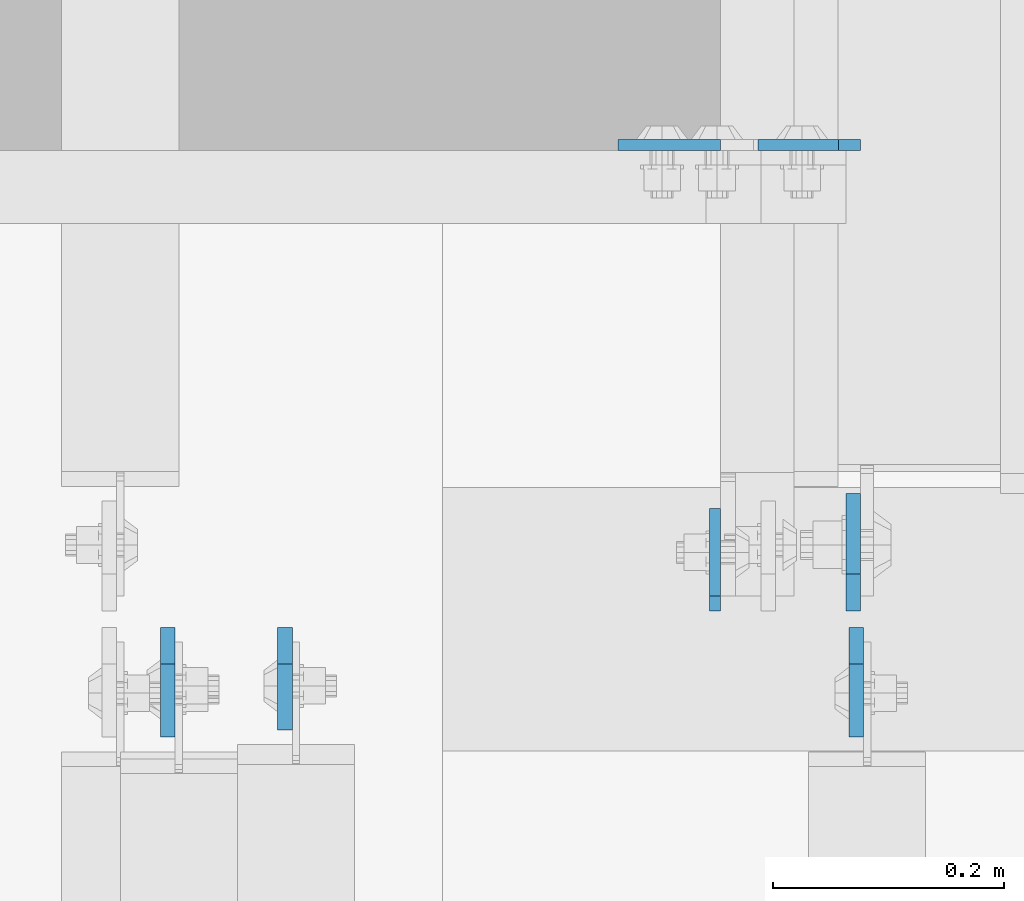
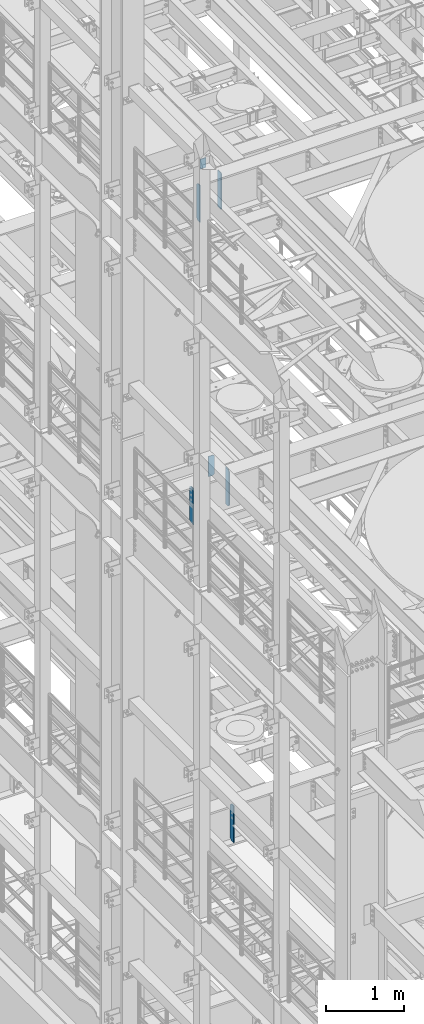
# One storey, part 1554 of 1876: 7 plates, 5 elements without a shape of their own.
"""IFC2X3 building model written with IfcOpenShell, lengths in millimetres."""

from ifc_helpers import new_model, si_unit, frame, origin_with_axes, place, context, subcontext, project, spatial, faceted_brep, material, type_object, element, aggregate, save


model = new_model("IFC2X3")

# Units and contexts
model_context = context("Model", 3, precision=1e-05, world=origin_with_axes())
body_context = subcontext(model_context, "Body", "Model", "MODEL_VIEW")
ifc_project = project(units=[si_unit("LENGTHUNIT", "METRE", prefix="MILLI"), si_unit("AREAUNIT", "SQUARE_METRE"), si_unit("VOLUMEUNIT", "CUBIC_METRE"), si_unit("MASSUNIT", "GRAM", prefix="KILO"), si_unit("TIMEUNIT", "SECOND"), si_unit("PLANEANGLEUNIT", "RADIAN"), si_unit("SOLIDANGLEUNIT", "STERADIAN"), si_unit("THERMODYNAMICTEMPERATUREUNIT", "DEGREE_CELSIUS"), si_unit("LUMINOUSINTENSITYUNIT", "LUMEN")], contexts=[model_context])

# Site, building, storey
site_placement = place(None, origin_with_axes())
site = spatial("IfcSite", under=ifc_project, at=site_placement, CompositionType="ELEMENT")
building_placement = place(site_placement, origin_with_axes())
building = spatial("IfcBuilding", under=site, at=building_placement, Name="Undefined", CompositionType="ELEMENT")
storey_placement = place(building_placement, origin_with_axes())
storey = spatial("IfcBuildingStorey", under=building, at=storey_placement, Name="Undefined", CompositionType="ELEMENT", Elevation=0.0)

# Assembly, plate
assembly_1_placement = place(storey_placement, origin_with_axes())
assembly_1 = element("IfcElementAssembly", 1, at=assembly_1_placement, inside=storey, Name="BEAM", AssemblyPlace="NOTDEFINED", PredefinedType="RIGID_FRAME")
ifc_material = material(Name="STEEL/A36")
plate_type_1 = type_object("IfcPlateType", PredefinedType="NOTDEFINED")
plate_1_placement = place(assembly_1_placement, frame((1473.2, 1935.1625, 17957.8), z_axis=(-1.0, 0.0, 0.0), x_axis=(0.0, 0.0, -1.0)))
plate_1 = element("IfcPlate", 2, at=plate_1_placement, type_object=plate_type_1, material=ifc_material, Name="PLATE", context=body_context, shape_type="Brep", body=[
    faceted_brep([(0.0, -4.76249999999982, 0.0), (0.0, -4.76249999999982, 88.9000015258789), (0.0, 4.76249999999982, 88.9000015258789), (0.0, 4.76249999999982, 0.0), (152.399993896484, -4.76249999999982, 88.9000015258789), (152.399993896484, 4.76249999999982, 88.9000015258789), (152.399993896484, -4.76249999999982, 0.0), (152.399993896484, 4.76249999999982, 0.0)], [[[0, 1, 2, 3]], [[1, 4, 5, 2]], [[4, 6, 7, 5]], [[6, 0, 3, 7]], [[5, 7, 3, 2]], [[6, 4, 1, 0]]]),
])
aggregate(assembly_1, [plate_1])

assembly_2_placement = place(storey_placement, origin_with_axes())
assembly_2 = element("IfcElementAssembly", 3, at=assembly_2_placement, inside=storey, Name="BEAM", AssemblyPlace="NOTDEFINED", PredefinedType="RIGID_FRAME")
plate_2_placement = place(assembly_2_placement, frame((1468.43700008392, 1531.14375, 17386.3), z_axis=(0.0, 0.0, 1.0), x_axis=(0.0, 1.0, 0.0)))
plate_2 = element("IfcPlate", 4, at=plate_2_placement, type_object=plate_type_1, material=ifc_material, Name="PLATE", context=body_context, shape_type="Brep", body=[
    faceted_brep([(3.7040990719106e-08, -4.76249999999982, 12.6999998092651), (0.0, -4.76250000000005, 558.800000190735), (0.0, 4.76250000000005, 558.800000190735), (3.70396264770534e-08, 4.76249999999982, 12.6999998092651), (12.6999998092651, -4.76250000000005, 571.5), (12.6999998092651, 4.76250000000005, 571.5), (88.9000015258789, -4.76250000000005, 571.5), (88.9000015258789, 4.76250000000005, 571.5), (88.9000015258789, -4.76249999999982, 0.0), (88.9000015258789, 4.76249999999982, 0.0), (12.699999809267, -4.76249999999754, 1.09139364212751e-11), (12.6999998092651, 4.76250000000255, 1.09139364212751e-11)], [[[0, 1, 2, 3]], [[1, 4, 5, 2]], [[4, 6, 7, 5]], [[6, 8, 9, 7]], [[8, 10, 11, 9]], [[10, 0, 3, 11]], [[5, 7, 9, 11, 3, 2]], [[10, 8, 6, 4, 1, 0]]]),
])

assembly_3_placement = place(storey_placement, origin_with_axes())
assembly_3 = element("IfcElementAssembly", 5, at=assembly_3_placement, inside=storey, Name="BEAM", AssemblyPlace="NOTDEFINED", PredefinedType="RIGID_FRAME")
plate_3_placement = place(assembly_3_placement, frame((1594.64375, 1935.16299991608, 12974.6375), z_axis=(0.0, 0.0, 1.0), x_axis=(-1.0, 0.0, 0.0)))
plate_3 = element("IfcPlate", 6, at=plate_3_placement, type_object=plate_type_1, material=ifc_material, Name="PLATE", context=body_context, shape_type="Brep", body=[
    faceted_brep([(0.0, -4.76249999999982, 19.0499992370605), (-1.81898940354586e-12, -4.76250000000073, 296.862499237061), (0.0, 4.76249999999982, 296.862499237061), (0.0, 4.76249999999982, 19.0499992370605), (19.0499992370605, -4.76249999999982, 315.912506103516), (19.0499992370605, 4.76249999999982, 315.912506103516), (88.9000015258789, -4.76249999999982, 315.912506103516), (88.9000015258789, 4.76249999999982, 315.912506103516), (88.9000015258789, -4.76249999999982, 0.0), (88.9000015258789, 4.76249999999982, 0.0), (19.0499992370605, -4.76249999999982, 0.0), (19.0499992370605, 4.76249999999982, 0.0)], [[[0, 1, 2, 3]], [[1, 4, 5, 2]], [[4, 6, 7, 5]], [[6, 8, 9, 7]], [[8, 10, 11, 9]], [[10, 0, 3, 11]], [[5, 7, 9, 11, 3, 2]], [[10, 8, 6, 4, 1, 0]]]),
])
aggregate(assembly_3, [plate_3])

# Plate
plate_type_2 = type_object("IfcPlateType", PredefinedType="NOTDEFINED")
plate_4_placement = place(assembly_2_placement, frame((1095.37500024689, 1516.85625, 17386.3), z_axis=(0.0, 0.0, 1.0), x_axis=(0.0, -1.0, 0.0)))
plate_4 = element("IfcPlate", 7, at=plate_4_placement, type_object=plate_type_2, material=ifc_material, Name="PLATE", context=body_context, shape_type="Brep", body=[
    faceted_brep([(0.0, -6.34999999999991, 31.75), (0.0, -6.34999999999991, 539.75), (0.0, 6.34999999999991, 539.75), (0.0, 6.34999999999991, 31.75), (31.75, -6.34999999999991, 571.5), (31.75, 6.34999999999991, 571.5), (88.9000015258789, -6.34999999999991, 571.5), (88.9000015258789, 6.34999999999991, 571.5), (88.9000015258789, -6.34999999999991, 0.0), (88.9000015258789, 6.34999999999991, 0.0), (31.75, -6.34999999999991, 0.0), (31.75, 6.34999999999991, 0.0)], [[[0, 1, 2, 3]], [[1, 4, 5, 2]], [[4, 6, 7, 5]], [[6, 8, 9, 7]], [[8, 10, 11, 9]], [[10, 0, 3, 11]], [[5, 7, 9, 11, 3, 2]], [[10, 8, 6, 4, 1, 0]]]),
])

aggregate(assembly_2, [plate_4, plate_2])

# Assembly, plate
assembly_4_placement = place(storey_placement, origin_with_axes())
assembly_4 = element("IfcElementAssembly", 8, at=assembly_4_placement, inside=storey, Name="BEAM", AssemblyPlace="NOTDEFINED", PredefinedType="RIGID_FRAME")
plate_type_3 = type_object("IfcPlateType", PredefinedType="NOTDEFINED")
plate_5_placement = place(assembly_4_placement, frame((1590.67499990463, 1516.85625, 7558.0875), z_axis=(0.0, 0.0, 1.0), x_axis=(0.0, -1.0, 0.0)))
plate_5 = element("IfcPlate", 9, at=plate_5_placement, type_object=plate_type_3, material=ifc_material, Name="PLATE", context=body_context, shape_type="Brep", body=[
    faceted_brep([(0.0, -6.34999999999991, 31.75), (0.0, -6.35000000000036, 538.162475585938), (0.0, 6.35000000000036, 538.162475585938), (0.0, 6.34999999999991, 31.75), (31.75, -6.35000000000036, 569.912475585938), (31.75, 6.35000000000036, 569.912475585938), (95.25, -6.35000000000036, 569.912475585938), (95.25, 6.35000000000036, 569.912475585938), (95.25, -6.35000000000036, 0.0), (95.25, 6.35000000000036, 0.0), (31.75, -6.34999999999991, 0.0), (31.75, 6.34999999999991, 0.0)], [[[0, 1, 2, 3]], [[1, 4, 5, 2]], [[4, 6, 7, 5]], [[6, 8, 9, 7]], [[8, 10, 11, 9]], [[10, 0, 3, 11]], [[5, 7, 9, 11, 3, 2]], [[10, 8, 6, 4, 1, 0]]]),
])
aggregate(assembly_4, [plate_5])

# Assembly, plates
assembly_5_placement = place(storey_placement, origin_with_axes())
assembly_5 = element("IfcElementAssembly", 10, at=assembly_5_placement, inside=storey, Name="BEAM", AssemblyPlace="NOTDEFINED", PredefinedType="RIGID_FRAME")
plate_6_placement = place(assembly_5_placement, frame((993.774999891861, 1516.85625, 12714.2875), z_axis=(0.0, 0.0, 1.0), x_axis=(0.0, -1.0, 0.0)))
plate_6 = element("IfcPlate", 11, at=plate_6_placement, type_object=plate_type_3, material=ifc_material, Name="PLATE", context=body_context, shape_type="Brep", body=[
    faceted_brep([(0.0, -6.34999999999991, 31.75), (0.0, -6.35000000000036, 538.162475585938), (0.0, 6.35000000000036, 538.162475585938), (0.0, 6.34999999999991, 31.75), (31.75, -6.35000000000036, 569.912475585938), (31.75, 6.35000000000036, 569.912475585938), (95.25, -6.35000000000036, 569.912475585938), (95.25, 6.35000000000036, 569.912475585938), (95.25, -6.35000000000036, 0.0), (95.25, 6.35000000000036, 0.0), (31.75, -6.34999999999991, 0.0), (31.75, 6.34999999999991, 0.0)], [[[0, 1, 2, 3]], [[1, 4, 5, 2]], [[4, 6, 7, 5]], [[6, 8, 9, 7]], [[8, 10, 11, 9]], [[10, 0, 3, 11]], [[5, 7, 9, 11, 3, 2]], [[10, 8, 6, 4, 1, 0]]]),
])
plate_type_4 = type_object("IfcPlateType", PredefinedType="NOTDEFINED")
plate_7_placement = place(assembly_5_placement, frame((1588.29374990463, 1531.14375, 12714.2875), z_axis=(0.0, 0.0, 1.0), x_axis=(0.0, 1.0, 0.0)))
plate_7 = element("IfcPlate", 12, at=plate_7_placement, type_object=plate_type_4, material=ifc_material, Name="PLATE", context=body_context, shape_type="Brep", body=[
    faceted_brep([(0.0, -6.34999999999991, 31.75), (0.0, -6.35000000000036, 538.162475585938), (0.0, 6.35000000000036, 538.162475585938), (0.0, 6.34999999999991, 31.75), (31.75, -6.35000000000036, 569.912475585938), (31.75, 6.35000000000036, 569.912475585938), (101.599998474121, -6.34999999999991, 569.912475585938), (101.599998474121, 6.34999999999991, 569.912475585938), (101.599998474121, -6.35000000000036, 0.0), (101.599998474121, 6.35000000000036, 0.0), (31.75, -6.34999999999991, 0.0), (31.75, 6.34999999999991, 0.0)], [[[0, 1, 2, 3]], [[1, 4, 5, 2]], [[4, 6, 7, 5]], [[6, 8, 9, 7]], [[8, 10, 11, 9]], [[10, 0, 3, 11]], [[5, 7, 9, 11, 3, 2]], [[10, 8, 6, 4, 1, 0]]]),
])
aggregate(assembly_5, [plate_7, plate_6])

save(model, "model.ifc")
